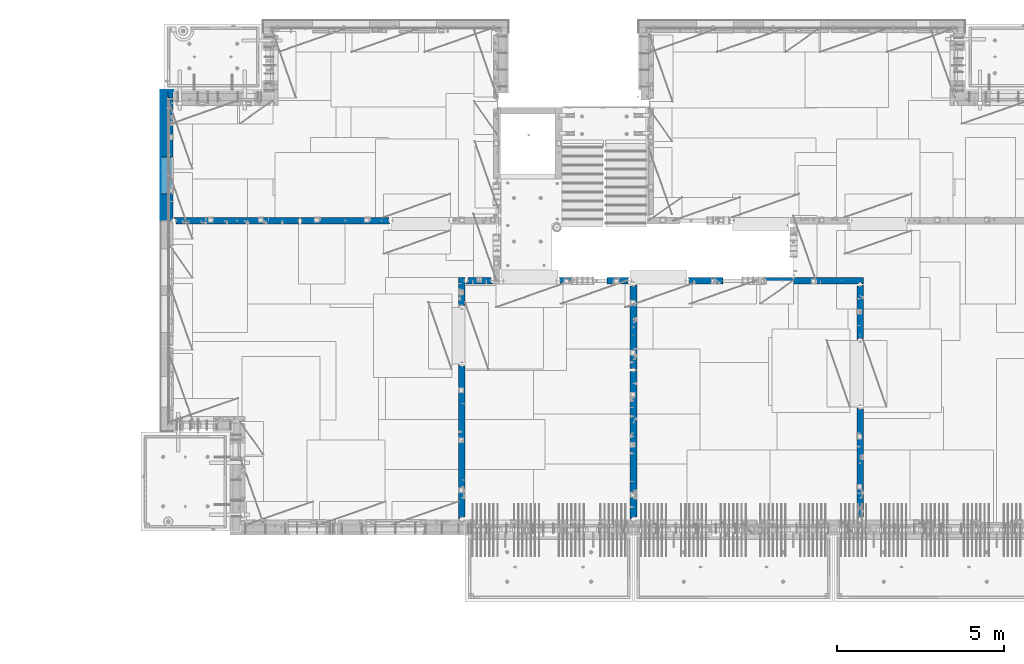
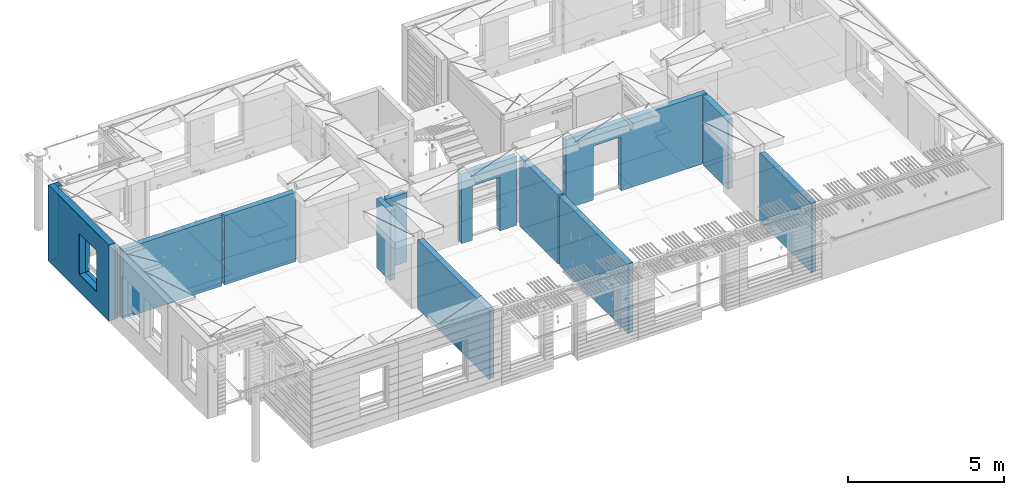
# One storey, part 224 of 334: 16 walls, 12 elements without a shape of their own.
"""IFC2X3 building model written with IfcOpenShell, lengths in millimetres."""

from ifc_helpers import new_model, si_unit, frame, origin_with_axes, place, context, subcontext, project, spatial, faceted_brep, material, type_object, element, aggregate, save


model = new_model("IFC2X3")

# Units and contexts
model_context = context("Model", 3, precision=1e-05, world=origin_with_axes())
body_context = subcontext(model_context, "Body", "Model", "MODEL_VIEW")
ifc_project = project(units=[si_unit("LENGTHUNIT", "METRE", prefix="MILLI"), si_unit("AREAUNIT", "SQUARE_METRE"), si_unit("VOLUMEUNIT", "CUBIC_METRE"), si_unit("MASSUNIT", "GRAM", prefix="KILO"), si_unit("TIMEUNIT", "SECOND"), si_unit("PLANEANGLEUNIT", "RADIAN"), si_unit("SOLIDANGLEUNIT", "STERADIAN"), si_unit("THERMODYNAMICTEMPERATUREUNIT", "DEGREE_CELSIUS"), si_unit("LUMINOUSINTENSITYUNIT", "LUMEN")], contexts=[model_context])

# Site, building, storey
site_placement = place(None, origin_with_axes())
site = spatial("IfcSite", under=ifc_project, at=site_placement, CompositionType="ELEMENT")
building_placement = place(site_placement, origin_with_axes())
building = spatial("IfcBuilding", under=site, at=building_placement, CompositionType="ELEMENT")
storey_placement = place(building_placement, origin_with_axes())
storey = spatial("IfcBuildingStorey", under=building, at=storey_placement, Name="3", CompositionType="ELEMENT", Elevation=0.0)

# Assembly, wall
assembly_1_placement = place(storey_placement, origin_with_axes())
assembly_1 = element("IfcElementAssembly", 1, at=assembly_1_placement, inside=storey, AssemblyPlace="NOTDEFINED", PredefinedType="REINFORCEMENT_UNIT")
ifc_material_1 = material(Name="CONCRETE/C25/30")
wall_type_1 = type_object("IfcWallType", PredefinedType="NOTDEFINED")
wall_1_placement = place(assembly_1_placement, frame((23410.0002919986, 15180.0, 89112.5), z_axis=(0.0, 0.0, 1.0), x_axis=(1.0, 0.0, 0.0)))
wall_1 = element("IfcWall", 2, at=wall_1_placement, type_object=wall_type_1, material=ifc_material_1, context=body_context, shape_type="Brep", body=[
    faceted_brep([(3134.99885559082, 100.0, 762.5), (3147.99885559082, 80.0, 762.5), (3251.99885559082, 80.0, 762.5), (3264.99885559082, 100.0, 762.5), (3147.99885559082, 80.0, 1357.5), (3134.99885559082, 100.0, 1357.5), (3251.99885559082, 80.0, 1357.5), (3264.99885559082, 100.0, 1357.5), (5299.99970800144, -100.0, -1357.5), (5299.99970800144, -100.0, 1357.5), (5264.99970800144, -100.0, 1357.5), (5264.99970800144, -100.0, -1357.5), (5251.99970800144, -70.0, 1357.5), (5251.99970800144, -70.0, -1357.5), (5147.99970800144, -70.0, 1357.5), (5147.99970800144, -70.0, -1357.5), (5134.99970800144, -100.0, 1357.5), (5134.99970800144, -100.0, -1357.5), (59.9988535092562, -100.0, 1357.5), (59.9988535092562, -100.0, -1357.5), (1090.00039464695, -100.0, -1357.5), (1090.00039464695, -100.0, 762.5), (2110.00039464695, -100.0, 762.5), (2110.00039464695, -100.0, -1357.5), (59.9988535092562, 57.0, 1357.5), (59.9988535092562, 57.0, -1357.5), (29.9988535092562, 70.0000000000018, 1357.5), (29.9988535092562, 70.0000000000018, -1357.5), (29.9988535092562, 100.0, 1357.5), (29.9988535092562, 100.0, -1357.5), (1090.00039464695, 100.0, -1357.5), (1090.00039464695, 100.0, 762.5), (2110.00039464695, 100.0, 762.5), (2110.00039464695, 100.0, -1357.5), (5299.99970800144, 100.0, -1357.5), (5299.99970800144, 100.0, 1357.5)], [[[0, 1, 2, 3]], [[4, 1, 0, 5]], [[6, 2, 1, 4]], [[7, 3, 2, 6]], [[8, 9, 10, 11]], [[10, 12, 13, 11]], [[14, 15, 13, 12]], [[16, 17, 15, 14]], [[17, 16, 18, 19, 20, 21, 22, 23]], [[24, 25, 19, 18]], [[26, 27, 25, 24]], [[28, 29, 27, 26]], [[19, 25, 27, 29, 30, 20]], [[31, 21, 20, 30]], [[32, 22, 21, 31]], [[33, 23, 22, 32]], [[34, 8, 11, 13, 15, 17, 23, 33]], [[9, 8, 34, 35]], [[4, 5, 28, 26, 24, 18, 16, 14, 12, 10, 9, 35, 7, 6]], [[35, 34, 33, 32, 31, 30, 29, 28, 5, 0, 3, 7]]]),
])
aggregate(assembly_1, [wall_1])

assembly_2_placement = place(storey_placement, origin_with_axes())
assembly_2 = element("IfcElementAssembly", 3, at=assembly_2_placement, inside=storey, AssemblyPlace="NOTDEFINED", PredefinedType="REINFORCEMENT_UNIT")
wall_2_placement = place(assembly_2_placement, frame((19569.9991455076, 15180.0000000001, 89112.5), z_axis=(0.0, 0.0, 1.0), x_axis=(1.0, 0.0, 0.0)))
wall_2 = element("IfcWall", 4, at=wall_2_placement, type_object=wall_type_1, material=ifc_material_1, context=body_context, shape_type="Brep", body=[
    faceted_brep([(30.0000000001819, 56.9999999999745, 1357.5), (30.0000000001819, 56.9999999999745, -1357.5), (30.0000000001819, -100.0, -1357.5), (30.0000000001819, -100.0, 1357.5), (0.0, 69.9999999999745, 1357.5), (0.0, 69.9999999999745, -1357.5), (1450.00154113788, 100.0, -1357.5), (1450.00154113788, -100.0, -1357.5), (1450.00154113788, -100.0, 762.5), (1450.00154113788, 100.0, 762.5), (430.001541137881, 100.0, 762.5), (430.001541137881, -100.0, 762.5), (430.001541137881, -100.0, -1357.5), (430.001541137881, 100.0, -1357.5), (0.0, 100.0, -1357.5), (0.0, 100.0, 1357.5), (2110.00085449221, 100.0, 1357.5), (2110.00085449221, 100.0, -1357.5), (2110.00085449272, 70.0000000037435, 1357.5), (2110.00085449221, 70.0000000037435, -1357.5), (2080.00085191853, -100.0, -1357.5), (2080.00085558004, 57.0000004585763, -1357.5), (2080.00085558004, 57.0000004585763, 1357.5), (2080.00085191853, -100.0, 1357.5)], [[[0, 1, 2, 3]], [[4, 5, 1, 0]], [[6, 7, 8, 9]], [[10, 11, 12, 13]], [[9, 8, 11, 10]], [[13, 14, 15, 16, 17, 6, 9, 10]], [[17, 16, 18, 19]], [[20, 7, 6, 17, 19, 21]], [[18, 22, 21, 19]], [[23, 20, 21, 22]], [[12, 11, 8, 7, 20, 23, 3, 2]], [[14, 13, 12, 2, 1, 5]], [[15, 14, 5, 4]], [[23, 22, 18, 16, 15, 4, 0, 3]]]),
])
aggregate(assembly_2, [wall_2])

assembly_3_placement = place(storey_placement, origin_with_axes())
assembly_3 = element("IfcElementAssembly", 5, at=assembly_3_placement, inside=storey, AssemblyPlace="NOTDEFINED", PredefinedType="REINFORCEMENT_UNIT")
wall_3_placement = place(assembly_3_placement, frame((16790.0, 15180.0, 89112.5), z_axis=(0.0, 0.0, 1.0), x_axis=(1.0, 0.0, 0.0)))
wall_3 = element("IfcWall", 6, at=wall_3_placement, type_object=wall_type_1, material=ifc_material_1, context=body_context, shape_type="Brep", body=[
    faceted_brep([(740.0, 100.0, 1357.5), (740.0, -57.0, 1357.5), (740.0, -57.0, -1357.5), (740.0, 100.0, -1357.5), (790.0, -70.0, 1357.5), (790.0, -69.9999999999982, -1357.5), (50.0, 100.0, 1357.5), (50.0, 100.0, -1357.5), (50.0, -48.3299999999999, -1357.5), (50.0, -48.3299999999999, 1357.5), (0.0, -69.996666666666, -1357.5), (0.0, -69.996666666666, 1357.5), (0.0, -100.0, -1357.5), (0.0, -100.0, 1357.5), (790.0, -100.0, -1357.5), (790.0, -100.0, 1357.5)], [[[0, 1, 2, 3]], [[4, 5, 2, 1]], [[6, 7, 8, 9]], [[9, 8, 10, 11]], [[12, 13, 11, 10]], [[13, 12, 14, 15]], [[1, 0, 6, 9, 11, 13, 15, 4]], [[7, 6, 0, 3]], [[14, 12, 10, 8, 7, 3, 2, 5]], [[15, 14, 5, 4]]]),
])
aggregate(assembly_3, [wall_3])

assembly_4_placement = place(storey_placement, origin_with_axes())
assembly_4 = element("IfcElementAssembly", 7, at=assembly_4_placement, inside=storey, AssemblyPlace="NOTDEFINED", PredefinedType="REINFORCEMENT_UNIT")
wall_4_placement = place(assembly_4_placement, frame((16660.0, 14375.0001284873, 89112.5), z_axis=(0.0, 0.0, 1.0), x_axis=(0.0, 1.0, 0.0)))
wall_4 = element("IfcWall", 8, at=wall_4_placement, type_object=wall_type_1, material=ifc_material_1, context=body_context, shape_type="Brep", body=[
    faceted_brep([(59.9783637637502, 57.008280238686, -607.5), (29.9765698802239, 70.004139724977, -607.5), (29.972430061518, 100.0, -607.5), (84.972430061518, 100.0, -607.5), (84.972430061518, 50.0, -607.5), (59.9793309975266, 50.0, -607.5), (84.972430061518, 50.0, -1357.5), (84.972430061518, 100.0, -1357.5), (59.9793309975285, 50.0, -1357.5), (739.999871512746, -100.0, 1357.5), (752.999871512742, -80.0, 1357.5), (856.999871512742, -80.0, 1357.5), (869.99987151274, -100.0, 1357.5), (904.999871512742, -100.0, 1357.5), (904.999871512742, 100.0, 1357.5), (29.972430061518, 100.0, 1357.5), (29.9765698802239, 70.004139724977, 1357.5), (59.9783637637502, 57.008280238686, 1357.5), (60.0000329474624, -100.0, 1357.5), (739.999871512746, -100.0, -1357.5), (60.0000329474624, -100.0, -1357.5), (752.999871512742, -80.0, -1357.5), (856.999871512742, -80.0, -1357.5), (869.99987151274, -100.0, -1357.5), (904.999871512742, -100.0, -1357.5), (904.999871512742, 100.0, -1357.5)], [[[0, 1, 2, 3, 4, 5]], [[6, 4, 3, 7]], [[8, 5, 4, 6]], [[9, 10, 11, 12, 13, 14, 15, 16, 17, 18]], [[19, 9, 18, 20]], [[9, 19, 21, 10]], [[10, 21, 22, 11]], [[12, 11, 22, 23]], [[24, 13, 12, 23]], [[13, 24, 25, 14]], [[15, 14, 25, 7, 3, 2]], [[16, 15, 2, 1]], [[17, 16, 1, 0]], [[20, 18, 17, 0, 5, 8]], [[25, 24, 23, 22, 21, 19, 20, 8, 6, 7]]]),
])
aggregate(assembly_4, [wall_4])

assembly_5_placement = place(storey_placement, origin_with_axes())
assembly_5 = element("IfcElementAssembly", 9, at=assembly_5_placement, inside=storey, AssemblyPlace="NOTDEFINED", PredefinedType="REINFORCEMENT_UNIT")
wall_5_placement = place(assembly_5_placement, frame((16660.0, 8000.0, 89112.5), z_axis=(0.0, 0.0, 1.0), x_axis=(0.0, 1.0, 0.0)))
wall_5 = element("IfcWall", 10, at=wall_5_placement, type_object=wall_type_1, material=ifc_material_1, context=body_context, shape_type="Brep", body=[
    faceted_brep([(30.0000000000009, 70.0, 1357.5), (30.0, 70.0, -1357.5), (80.0, 57.0, -1357.5), (79.99999955967, 57.0000001052285, 1357.5), (79.9999996695051, -100.0, 1357.5), (80.0, -100.0, -1357.5), (30.0, 100.0, -1357.5), (30.0000000000009, 100.0, 1357.5), (4644.99239711402, 100.0, 1357.5), (4644.99239711402, 100.0, -1357.5), (4644.99653549905, 70.0145277302508, 1357.5), (4644.99653549905, 70.0145277302508, -1357.5), (4614.97833252975, 57.001718635147, 1357.5), (4614.97833252975, 57.001718635147, -1357.5), (4615.00000080787, -100.0, 1357.5), (4615.00000080787, -100.0, -1357.5)], [[[0, 1, 2, 3]], [[4, 3, 2, 5]], [[6, 7, 8, 9]], [[9, 8, 10, 11]], [[12, 13, 11, 10]], [[14, 15, 13, 12]], [[15, 14, 4, 5]], [[1, 6, 9, 11, 13, 15, 5, 2]], [[7, 6, 1, 0]], [[14, 12, 10, 8, 7, 0, 3, 4]]]),
])
aggregate(assembly_5, [wall_5])

assembly_6_placement = place(storey_placement, origin_with_axes())
assembly_6 = element("IfcElementAssembly", 11, at=assembly_6_placement, inside=storey, AssemblyPlace="NOTDEFINED", PredefinedType="REINFORCEMENT_UNIT")
wall_6_placement = place(assembly_6_placement, frame((21810.0, 12500.0, 89112.5), z_axis=(0.0, 0.0, 1.0), x_axis=(0.0, 1.0, 0.0)))
wall_6 = element("IfcWall", 12, at=wall_6_placement, type_object=wall_type_1, material=ifc_material_1, context=body_context, shape_type="Brep", body=[
    faceted_brep([(2519.9998239177, -57.0, 1357.5), (2519.9998239177, -57.0, -1357.5), (2519.9998239177, 100.0, -1357.5), (2519.9998239177, 100.0, 1357.5), (2549.9998239177, -70.0, 1357.5), (2549.9998239177, -70.0, -1357.5), (45.0, 100.0, 1357.5), (45.0, 100.0, -1357.5), (45.0, -57.0, -1357.5), (45.0, -57.0, 1357.5), (15.0, -70.0, 1357.5), (15.0, -70.0000000000036, -1357.5), (15.0, -100.0, -1357.5), (15.0, -100.0, 1357.5), (2549.9998239177, -100.0, -1357.5), (2549.9998239177, -100.0, 1357.5)], [[[0, 1, 2, 3]], [[4, 5, 1, 0]], [[6, 7, 8, 9]], [[10, 9, 8, 11]], [[12, 13, 10, 11]], [[13, 12, 14, 15]], [[3, 6, 9, 10, 13, 15, 4, 0]], [[7, 6, 3, 2]], [[14, 12, 11, 8, 7, 2, 1, 5]], [[15, 14, 5, 4]]]),
])
aggregate(assembly_6, [wall_6])

assembly_7_placement = place(storey_placement, origin_with_axes())
assembly_7 = element("IfcElementAssembly", 13, at=assembly_7_placement, inside=storey, AssemblyPlace="NOTDEFINED", PredefinedType="REINFORCEMENT_UNIT")
wall_7_placement = place(assembly_7_placement, frame((21810.0, 8000.0, 89112.5), z_axis=(0.0, 0.0, 1.0), x_axis=(0.0, 1.0, 0.0)))
wall_7 = element("IfcWall", 14, at=wall_7_placement, type_object=wall_type_1, material=ifc_material_1, context=body_context, shape_type="Brep", body=[
    faceted_brep([(30.0000000000009, 70.0, 1357.5), (30.0, 70.0, -1357.5), (80.0, 57.0, -1357.5), (79.99999955967, 57.0000001052285, 1357.5), (79.9999996695051, -100.0, 1357.5), (80.0, -100.0, -1357.5), (30.0, 100.0, -1357.5), (30.0000000000009, 100.0, 1357.5), (4455.0, 100.0, 1357.5), (4455.0, 100.0, -1357.5), (4455.0, -57.0, 1357.5), (4455.0, -57.0, -1357.5), (4485.0, -70.0000000000036, 1357.5), (4485.0, -70.0000000000036, -1357.5), (4485.0, -100.0, 1357.5), (4485.0, -100.0, -1357.5)], [[[0, 1, 2, 3]], [[4, 3, 2, 5]], [[6, 7, 8, 9]], [[10, 11, 9, 8]], [[12, 13, 11, 10]], [[14, 15, 13, 12]], [[15, 14, 4, 5]], [[1, 6, 9, 11, 13, 15, 5, 2]], [[7, 6, 1, 0]], [[14, 12, 10, 8, 7, 0, 3, 4]]]),
])
aggregate(assembly_7, [wall_7])

assembly_8_placement = place(storey_placement, origin_with_axes())
assembly_8 = element("IfcElementAssembly", 15, at=assembly_8_placement, inside=storey, AssemblyPlace="NOTDEFINED", PredefinedType="REINFORCEMENT_UNIT")
wall_8_placement = place(assembly_8_placement, frame((28610.0, 13387.9996249472, 89112.5), z_axis=(0.0, 0.0, 1.0), x_axis=(0.0, 1.0, 0.0)))
wall_8 = element("IfcWall", 16, at=wall_8_placement, type_object=wall_type_1, material=ifc_material_1, context=body_context, shape_type="Brep", body=[
    faceted_brep([(30.9999999999982, 70.0000000000073, 1357.5), (30.9999999999982, 70.0000000000073, -1357.5), (60.9999999999982, 57.0000000000036, -1357.5), (60.9999999999982, 57.0000000000036, 1357.5), (60.9999999999982, -100.0, 1357.5), (60.9999999999982, -100.0, -1357.5), (30.9999999999982, 100.0, -1357.5), (30.9999999999982, 100.0, 1357.5), (1631.00037505278, 100.0, 1357.5), (1631.00037505278, 100.0, -1357.5), (1631.00037505278, -56.9999999999964, 1357.5), (1631.00037505278, -56.9999999999964, -1357.5), (1661.00037505278, -70.0, 1357.5), (1661.00037505278, -70.0, -1357.5), (1661.00037505278, -100.0, 1357.5), (1661.00037505278, -100.0, -1357.5)], [[[0, 1, 2, 3]], [[4, 3, 2, 5]], [[6, 7, 8, 9]], [[10, 11, 9, 8]], [[12, 13, 11, 10]], [[14, 15, 13, 12]], [[15, 14, 4, 5]], [[1, 6, 9, 11, 13, 15, 5, 2]], [[7, 6, 1, 0]], [[14, 12, 10, 8, 7, 0, 3, 4]]]),
])
aggregate(assembly_8, [wall_8])

assembly_9_placement = place(storey_placement, origin_with_axes())
assembly_9 = element("IfcElementAssembly", 17, at=assembly_9_placement, inside=storey, AssemblyPlace="NOTDEFINED", PredefinedType="REINFORCEMENT_UNIT")
wall_9_placement = place(assembly_9_placement, frame((28610.0, 8000.0, 89112.5), z_axis=(0.0, 0.0, 1.0), x_axis=(0.0, 1.0, 0.0)))
wall_9 = element("IfcWall", 18, at=wall_9_placement, type_object=wall_type_1, material=ifc_material_1, context=body_context, shape_type="Brep", body=[
    faceted_brep([(30.0000000000009, 70.0, 1357.5), (30.0, 70.0, -1357.5), (80.0, 57.0, -1357.5), (79.99999955967, 57.0000001052285, 1357.5), (79.9999996695051, -100.0, 1357.5), (80.0, -100.0, -1357.5), (30.0, 100.0, -1357.5), (30.0000000000009, 100.0, 1357.5), (3360.0, 100.0, 1357.5), (3360.0, 100.0, -1357.5), (3360.0, 70.0000000000073, 1357.5), (3360.0, 70.0000000000073, -1357.5), (3330.0, 57.0000000000036, 1357.5), (3330.0, 57.0000000000036, -1357.5), (3330.0, -100.0, 1357.5), (3330.0, -100.0, -1357.5)], [[[0, 1, 2, 3]], [[4, 3, 2, 5]], [[6, 7, 8, 9]], [[9, 8, 10, 11]], [[12, 13, 11, 10]], [[14, 15, 13, 12]], [[15, 14, 4, 5]], [[1, 6, 9, 11, 13, 15, 5, 2]], [[7, 6, 1, 0]], [[14, 12, 10, 8, 7, 0, 3, 4]]]),
])
aggregate(assembly_9, [wall_9])

assembly_10_placement = place(storey_placement, origin_with_axes())
assembly_10 = element("IfcElementAssembly", 19, at=assembly_10_placement, inside=storey, AssemblyPlace="NOTDEFINED", PredefinedType="REINFORCEMENT_UNIT")
wall_10_placement = place(assembly_10_placement, frame((11795.0, 16980.0, 89112.5), z_axis=(0.0, 0.0, 1.0), x_axis=(1.0, 0.0, 0.0)))
wall_10 = element("IfcWall", 20, at=wall_10_placement, type_object=wall_type_1, material=ifc_material_1, context=body_context, shape_type="Brep", body=[
    faceted_brep([(2680.0, 100.0, 1357.5), (2680.0, -57.0, 1357.5), (2680.0, -57.0, -1357.50000000001), (2680.0, 100.0, -1357.5), (2705.0, -67.8333333333321, 1357.5), (2705.0, -67.8333333333321, -1357.5), (25.0, 100.0, 1357.5), (25.0, 100.0, -1357.5), (25.0, 70.0000000000036, -1357.5), (25.0, 70.0000000000036, 1357.5), (55.0, 57.0, -1357.5), (55.0, 57.0, 1357.5), (55.0, -100.0, -1357.5), (55.0, -100.0, 1357.5), (2705.0, -100.0, -1357.5), (2705.0, -100.0, 1357.5)], [[[0, 1, 2, 3]], [[4, 5, 2, 1]], [[6, 7, 8, 9]], [[9, 8, 10, 11]], [[11, 10, 12, 13]], [[14, 15, 13, 12]], [[0, 6, 9, 11, 13, 15, 4, 1]], [[7, 6, 0, 3]], [[14, 12, 10, 8, 7, 3, 2, 5]], [[15, 14, 5, 4]]]),
])
aggregate(assembly_10, [wall_10])

assembly_11_placement = place(storey_placement, origin_with_axes())
assembly_11 = element("IfcElementAssembly", 21, at=assembly_11_placement, inside=storey, AssemblyPlace="NOTDEFINED", PredefinedType="REINFORCEMENT_UNIT")
wall_11_placement = place(assembly_11_placement, frame((8000.0, 16980.0, 89112.5), z_axis=(0.0, 0.0, 1.0), x_axis=(1.0, 0.0, 0.0)))
wall_11 = element("IfcWall", 22, at=wall_11_placement, type_object=wall_type_1, material=ifc_material_1, context=body_context, shape_type="Brep", body=[
    faceted_brep([(80.0, 52.0, 1357.5), (80.0, 52.0, -1357.5), (80.0, -100.0, -1357.5), (79.9999996695051, -100.0, 1357.5), (30.0000022791291, 65.0, 1357.5), (30.0000022791291, 65.0, -1357.5), (30.0, 100.0, -1357.5), (30.0000000000009, 100.0, 1357.5), (3790.0, 100.0, 1357.5), (3790.0, 100.0, -1357.5), (3790.0, 70.0000000000036, 1357.5), (3790.0, 70.0000000000036, -1357.5), (3760.0, 57.0, 1357.5), (3760.0, 57.0, -1357.5), (3760.0, -100.0, 1357.5), (3760.0, -100.0, -1357.5)], [[[0, 1, 2, 3]], [[4, 5, 1, 0]], [[6, 7, 8, 9]], [[9, 8, 10, 11]], [[10, 12, 13, 11]], [[14, 15, 13, 12]], [[15, 14, 3, 2]], [[6, 9, 11, 13, 15, 2, 1, 5]], [[7, 6, 5, 4]], [[14, 12, 10, 8, 7, 4, 0, 3]]]),
])
aggregate(assembly_11, [wall_11])

# Assembly, walls
assembly_12_placement = place(storey_placement, origin_with_axes())
assembly_12 = element("IfcElementAssembly", 23, at=assembly_12_placement, inside=storey, AssemblyPlace="NOTDEFINED", PredefinedType="REINFORCEMENT_UNIT")
ifc_material_2 = material()
wall_type_2 = type_object("IfcWallType", PredefinedType="NOTDEFINED")
wall_12_placement = place(assembly_12_placement, frame((7850.0, 20764.9951872276, 89247.5), z_axis=(0.0, 0.0, 1.0), x_axis=(1.0, 0.0, 0.0)))
wall_12 = element("IfcWall", 24, at=wall_12_placement, type_object=wall_type_2, material=ifc_material_2, context=body_context, shape_type="Brep", body=[
    faceted_brep([(0.0, 110.0, -1492.5), (0.0, 110.0, 1492.5), (150.0, 110.0, 1492.5), (150.0, 110.0, -1492.5), (0.0, -110.0, 1492.5), (150.0, -110.0, 1492.5), (0.0, -110.0, -1492.5), (150.0, -110.0, -1492.5)], [[[0, 1, 2, 3]], [[1, 4, 5, 2]], [[4, 6, 7, 5]], [[6, 0, 3, 7]], [[5, 7, 3, 2]], [[6, 4, 1, 0]]]),
])
wall_13_placement = place(assembly_12_placement, frame((7740.0, 16980.0, 89247.5), z_axis=(0.0, 0.0, 1.0), x_axis=(0.0, 1.0, 0.0)))
wall_13 = element("IfcWall", 25, at=wall_13_placement, type_object=wall_type_2, material=ifc_material_2, context=body_context, shape_type="Brep", body=[
    faceted_brep([(5.0, -110.0, 1492.5), (5.0, -110.0, -1492.5), (3894.99518722756, -110.0, -1492.5), (3894.99518722756, -110.0, 1492.5), (795.000410774857, -110.0, -802.5), (795.000410774857, -110.0, 807.5), (1905.00041077486, -110.0, 807.5), (1905.00041077486, -110.0, -802.5), (5.0, 110.0, 1492.5), (3894.99518722756, 110.0, 1492.5), (5.0, 110.0, -1492.5), (3894.99518722756, 110.0, -1492.5), (795.000410774857, 110.0, -802.5), (1905.00041077486, 110.0, -802.5), (1905.00041077486, 110.0, 807.5), (795.000410774857, 110.0, 807.5)], [[[0, 1, 2, 3], [4, 5, 6, 7]], [[8, 0, 3, 9]], [[1, 0, 8, 10]], [[1, 10, 11, 2]], [[3, 2, 11, 9]], [[10, 8, 9, 11], [12, 13, 14, 15]], [[6, 14, 13, 7]], [[5, 15, 14, 6]], [[4, 12, 15, 5]], [[7, 13, 12, 4]]]),
])
wall_type_3 = type_object("IfcWallType", PredefinedType="NOTDEFINED")
wall_14_placement = place(assembly_12_placement, frame((7925.0, 16980.0, 89112.5), z_axis=(0.0, 0.0, 1.0), x_axis=(0.0, 1.0, 0.0)))
wall_14 = element("IfcWall", 26, at=wall_14_placement, type_object=wall_type_3, material=ifc_material_1, context=body_context, shape_type="Brep", body=[
    faceted_brep([(1905.00041077486, -75.0000002638189, -667.5), (1905.00041077486, 75.0, -667.5), (795.000410774857, 75.0, -667.5), (795.000410774857, -75.0000006142109, -667.5), (795.000410774857, 75.0, 942.5), (795.000410774857, -75.0000013255412, 942.5), (1905.00041077486, 75.0, 942.5), (1905.00041077486, -75.0000009751493, 942.5), (3674.99518722756, -75.0, -1357.5), (3674.99518722756, -75.0, 1357.5), (3564.99519001209, -75.0000022791282, 1357.5), (3564.99519001209, -75.0, -1357.5), (3674.99518722756, 75.0, 1357.5), (5.0, 75.0, 1357.5), (5.0, -15.0000022791291, 1357.5), (65.0, -75.0, 1357.5), (3484.99518722756, -75.0000001199542, 1357.5), (3497.99518763813, -54.9999993903657, 1357.5), (3551.99518754267, -54.9999994175314, 1357.5), (5.0, 75.0, -1357.5), (5.0, -15.0000022791291, -1357.5), (65.0, -75.0, -1357.5), (3484.99518722756, -75.0, -1357.5), (3497.99518763813, -54.9999993903657, -1357.5), (3551.99518754267, -54.9999994175314, -1357.5), (3674.99518722756, 75.0, -1357.5)], [[[0, 1, 2, 3]], [[3, 2, 4, 5]], [[5, 4, 6, 7]], [[7, 6, 1, 0]], [[8, 9, 10, 11]], [[9, 12, 13, 14, 15, 16, 17, 18, 10]], [[13, 19, 20, 14]], [[15, 14, 20, 21]], [[15, 21, 22, 16], [3, 5, 7, 0]], [[16, 22, 23, 17]], [[17, 23, 24, 18]], [[10, 18, 24, 11]], [[23, 22, 21, 20, 19, 25, 8, 11, 24]], [[9, 8, 25, 12]], [[19, 13, 12, 25], [2, 1, 6, 4]]]),
])
ifc_material_3 = material(Name="CONCRETE/C30/37")
wall_type_4 = type_object("IfcWallType", PredefinedType="NOTDEFINED")
wall_15_placement = place(assembly_12_placement, frame((7630.0, 20879.9952125549, 89247.5), z_axis=(0.0, 0.0, 1.0), x_axis=(1.0, 0.0, 0.0)))
wall_15 = element("IfcWall", 27, at=wall_15_placement, type_object=wall_type_4, material=ifc_material_3, context=body_context, shape_type="Brep", body=[
    faceted_brep([(0.0, 5.0, -1492.5), (0.0, 5.0, 1492.5), (370.0, 5.0, 1492.5), (370.0, 5.0, -1492.5), (0.0, -5.0, 1492.5), (370.0, -5.0, 1492.5), (0.0, -5.0, -1492.5), (370.0, -5.0, -1492.5)], [[[0, 1, 2, 3]], [[1, 4, 5, 2]], [[4, 6, 7, 5]], [[6, 0, 3, 7]], [[5, 7, 3, 2]], [[6, 4, 1, 0]]]),
])
wall_16_placement = place(assembly_12_placement, frame((7625.0, 16980.0, 89247.5), z_axis=(0.0, 0.0, 1.0), x_axis=(0.0, 1.0, 0.0)))
wall_16 = element("IfcWall", 28, at=wall_16_placement, type_object=wall_type_4, material=ifc_material_3, context=body_context, shape_type="Brep", body=[
    faceted_brep([(5.0, -5.0, 1492.5), (5.0, -5.0, -1492.5), (3904.99518722756, -5.0, -1492.5), (3904.99518722756, -5.0, 1492.5), (795.000410774981, -5.0, -802.5), (795.000410774981, -5.0, 807.5), (1905.00041077498, -5.0, 807.5), (1905.00041077498, -5.0, -802.5), (5.0, 5.0, 1492.5), (3904.99518722756, 5.0, 1492.5), (5.0, 5.0, -1492.5), (3904.99518722756, 5.0, -1492.5), (795.000410774981, 5.0, -802.5), (1905.00041077498, 5.0, -802.5), (1905.00041077498, 5.0, 807.5), (795.000410774981, 5.0, 807.5)], [[[0, 1, 2, 3], [4, 5, 6, 7]], [[8, 0, 3, 9]], [[1, 0, 8, 10]], [[1, 10, 11, 2]], [[3, 2, 11, 9]], [[10, 8, 9, 11], [12, 13, 14, 15]], [[6, 14, 13, 7]], [[5, 15, 14, 6]], [[4, 12, 15, 5]], [[7, 13, 12, 4]]]),
])
aggregate(assembly_12, [wall_12, wall_15, wall_14, wall_13, wall_16])

save(model, "model.ifc")
